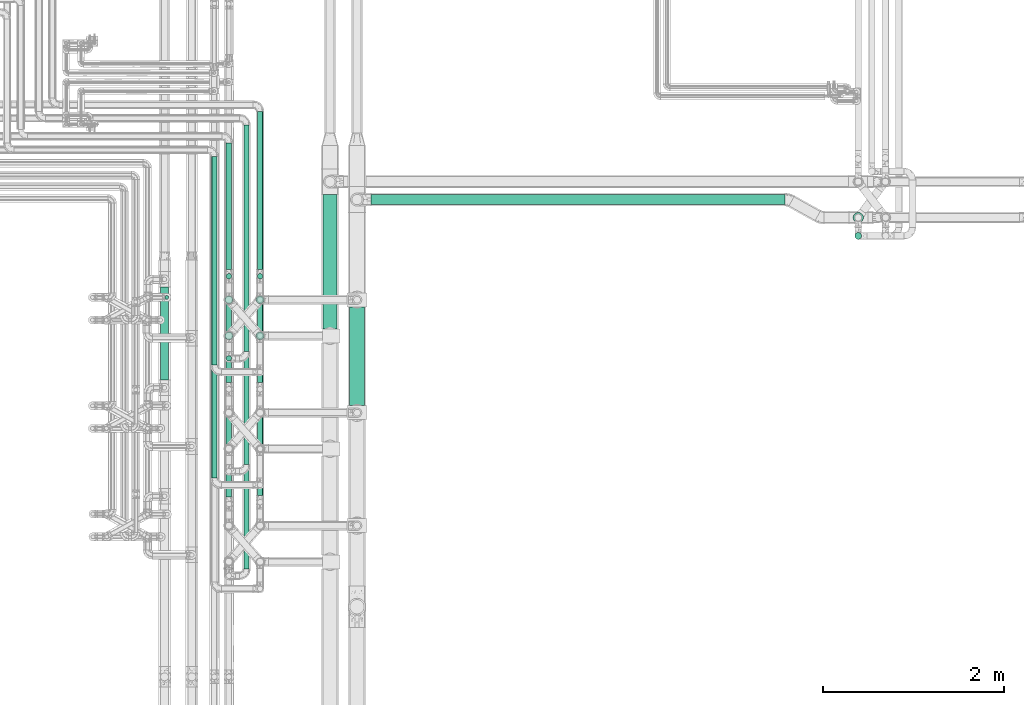
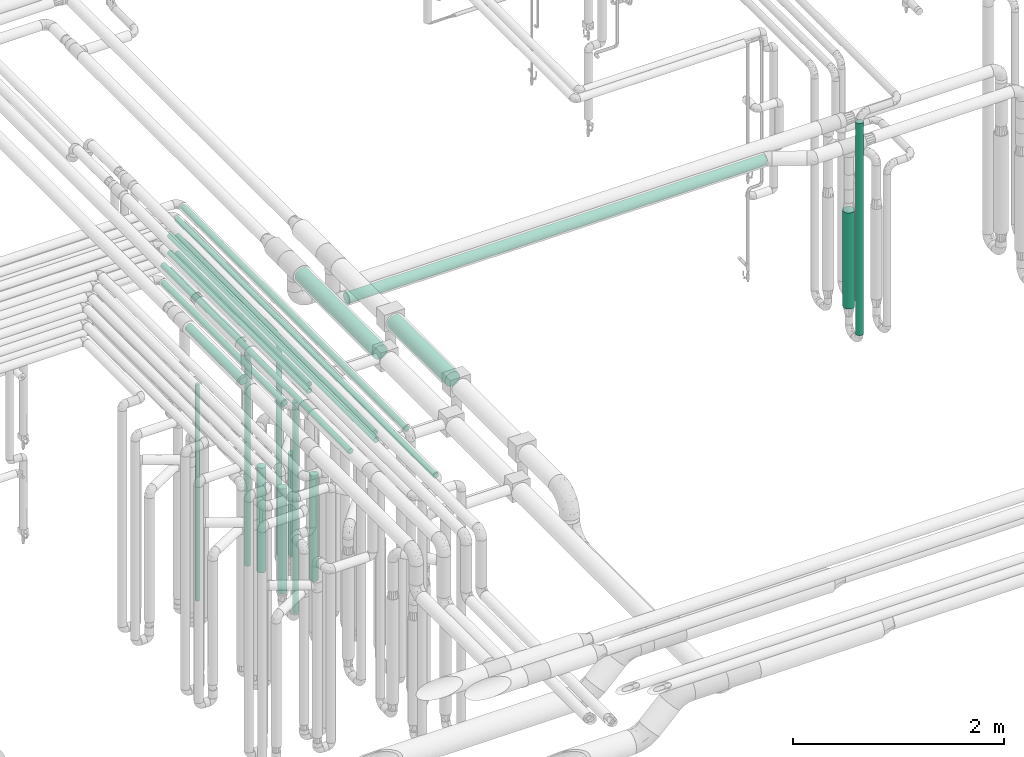
# One storey, part 531 of 827: 25 flow segments.
"""IFC2X3 building model written with IfcOpenShell, lengths in millimetres."""

from ifc_helpers import new_model, entity, si_unit, converted_unit, derived_unit, direction, frame, origin, origin_2d_with_axis, place, context, subcontext, project, spatial, circle, extrude, type_object, element, save


model = new_model("IFC2X3")

# Units and contexts
model_context = context("Model", 3, precision=0.01, world=origin(), true_north=direction((6.12303176911189e-17, 1.0)))
body_context = subcontext(model_context, "Body", "Model", "MODEL_VIEW")
ifc_project = project(units=[si_unit("LENGTHUNIT", "METRE", prefix="MILLI"), si_unit("AREAUNIT", "SQUARE_METRE"), si_unit("VOLUMEUNIT", "CUBIC_METRE"), converted_unit("PLANEANGLEUNIT", "DEGREE", entity("IfcRatioMeasure", 0.0174532925199433), si_unit("PLANEANGLEUNIT", "RADIAN"), dimensions=[0, 0, 0, 0, 0, 0, 0]), si_unit("MASSUNIT", "GRAM", prefix="KILO"), derived_unit("MASSDENSITYUNIT", [(si_unit("MASSUNIT", "GRAM", prefix="KILO"), 1), (si_unit("LENGTHUNIT", "METRE"), -3)]), derived_unit("MOMENTOFINERTIAUNIT", [(si_unit("LENGTHUNIT", "METRE"), 4)]), si_unit("TIMEUNIT", "SECOND"), si_unit("FREQUENCYUNIT", "HERTZ"), si_unit("THERMODYNAMICTEMPERATUREUNIT", "DEGREE_CELSIUS"), derived_unit("THERMALTRANSMITTANCEUNIT", [(si_unit("MASSUNIT", "GRAM", prefix="KILO"), 1), (si_unit("THERMODYNAMICTEMPERATUREUNIT", "KELVIN"), -1), (si_unit("TIMEUNIT", "SECOND"), -3)]), derived_unit("VOLUMETRICFLOWRATEUNIT", [(si_unit("LENGTHUNIT", "METRE"), 3), (si_unit("TIMEUNIT", "SECOND"), -1)]), derived_unit("MASSFLOWRATEUNIT", [(si_unit("MASSUNIT", "GRAM", prefix="KILO"), 1), (si_unit("TIMEUNIT", "SECOND"), -1)]), derived_unit("ROTATIONALFREQUENCYUNIT", [(si_unit("TIMEUNIT", "SECOND"), -1)]), si_unit("ELECTRICCURRENTUNIT", "AMPERE"), si_unit("ELECTRICVOLTAGEUNIT", "VOLT"), si_unit("POWERUNIT", "WATT"), si_unit("FORCEUNIT", "NEWTON", prefix="KILO"), si_unit("ILLUMINANCEUNIT", "LUX"), si_unit("LUMINOUSFLUXUNIT", "LUMEN"), si_unit("LUMINOUSINTENSITYUNIT", "CANDELA"), derived_unit("USERDEFINED", [(si_unit("MASSUNIT", "GRAM", prefix="KILO"), -1), (si_unit("LENGTHUNIT", "METRE"), -2), (si_unit("TIMEUNIT", "SECOND"), 3), (si_unit("LUMINOUSFLUXUNIT", "LUMEN"), 1)]), derived_unit("LINEARVELOCITYUNIT", [(si_unit("LENGTHUNIT", "METRE"), 1), (si_unit("TIMEUNIT", "SECOND"), -1)]), si_unit("PRESSUREUNIT", "PASCAL"), derived_unit("USERDEFINED", [(si_unit("LENGTHUNIT", "METRE"), -2), (si_unit("MASSUNIT", "GRAM", prefix="KILO"), 1), (si_unit("TIMEUNIT", "SECOND"), -2)]), derived_unit("LINEARFORCEUNIT", [(si_unit("MASSUNIT", "GRAM", prefix="KILO"), 1), (si_unit("LENGTHUNIT", "METRE"), 1), (si_unit("TIMEUNIT", "SECOND"), -2), (si_unit("LENGTHUNIT", "METRE"), -1)]), derived_unit("PLANARFORCEUNIT", [(si_unit("MASSUNIT", "GRAM", prefix="KILO"), 1), (si_unit("LENGTHUNIT", "METRE"), 1), (si_unit("TIMEUNIT", "SECOND"), -2), (si_unit("LENGTHUNIT", "METRE"), -2)])], contexts=[model_context])

# Site, building, storey
site_placement = place(None, origin())
site = spatial("IfcSite", under=ifc_project, at=site_placement, CompositionType="ELEMENT")
building_placement = place(site_placement, origin())
building = spatial("IfcBuilding", under=site, at=building_placement, CompositionType="ELEMENT")
storey_placement = place(building_placement, frame((0.0, 0.0, 28200.0)))
storey = spatial("IfcBuildingStorey", under=building, at=storey_placement, Name="08", CompositionType="ELEMENT", Elevation=28200.0)

# Flow segments
pipe_segment_type_1 = type_object("IfcPipeSegmentType", PredefinedType="NOTDEFINED")
flow_segment_1_placement = place(storey_placement, frame((37667.2, 12658.67, 2818.81)))
element("IfcFlowSegment", 1, at=flow_segment_1_placement, inside=storey, type_object=pipe_segment_type_1, context=body_context, shape_type="SweptSolid", body=[
    extrude(circle(Radius=79.5, at=origin_2d_with_axis()), frame((81.1, 0.0, 81.1), z_axis=(0.0, 1.0, 0.0), x_axis=(1.0, 0.0, 0.0)), (0.0, 0.0, 1.0), 1484.9489797613),
])
pipe_segment_type_2 = type_object("IfcPipeSegmentType", PredefinedType="NOTDEFINED")
flow_segment_2_placement = place(storey_placement, frame((38200.3, 14030.32, 2441.4)))
element("IfcFlowSegment", 2, at=flow_segment_2_placement, inside=storey, type_object=pipe_segment_type_2, context=body_context, shape_type="SweptSolid", body=[
    extrude(circle(Radius=57.0, at=origin_2d_with_axis()), frame((0.0, 58.6, 58.6), z_axis=(1.0, 0.0, 0.0), x_axis=(0.0, 1.0, 0.0)), (0.0, 0.0, 1.0), 4582.2791782302),
])
flow_segment_3_placement = place(storey_placement, frame((43556.18, 13647.49, 445.0)))
element("IfcFlowSegment", 3, at=flow_segment_3_placement, inside=storey, type_object=pipe_segment_type_2, context=body_context, shape_type="SweptSolid", body=[
    extrude(circle(Radius=37.75, at=origin_2d_with_axis()), frame((39.35, 39.35, 0.0), z_axis=(0.0, 0.0, 1.0), x_axis=(-1.0, 0.0, 0.0)), (0.0, 0.0, 1.0), 2460.0),
])
flow_segment_4_placement = place(storey_placement, frame((36438.44, 12257.17, 2968.4)))
element("IfcFlowSegment", 4, at=flow_segment_4_placement, inside=storey, type_object=pipe_segment_type_2, context=body_context, shape_type="SweptSolid", body=[
    extrude(circle(Radius=30.0, at=origin_2d_with_axis()), frame((31.6, 0.0, 31.6), z_axis=(0.0, 1.0, 0.0), x_axis=(1.0, 0.0, 0.0)), (0.0, 0.0, 1.0), 2306.8258040542),
])
flow_segment_5_placement = place(storey_placement, frame((36943.44, 13316.2, 2968.4)))
element("IfcFlowSegment", 5, at=flow_segment_5_placement, inside=storey, type_object=pipe_segment_type_2, context=body_context, shape_type="SweptSolid", body=[
    extrude(circle(Radius=30.0, at=origin_2d_with_axis()), frame((31.6, 0.0, 31.6), z_axis=(0.0, 1.0, 0.0), x_axis=(1.0, 0.0, 0.0)), (0.0, 0.0, 1.0), 1746.7974740542),
])
flow_segment_6_placement = place(storey_placement, frame((36793.44, 12407.17, 2968.4)))
element("IfcFlowSegment", 6, at=flow_segment_6_placement, inside=storey, type_object=pipe_segment_type_2, context=body_context, shape_type="SweptSolid", body=[
    extrude(circle(Radius=30.0, at=origin_2d_with_axis()), frame((31.6, 0.0, 31.6), z_axis=(0.0, 1.0, 0.0), x_axis=(-1.0, 0.0, 0.0)), (0.0, 0.0, 1.0), 2505.82601323927),
])
flow_segment_7_placement = place(storey_placement, frame((36598.05, 13316.2, 2968.4)))
element("IfcFlowSegment", 7, at=flow_segment_7_placement, inside=storey, type_object=pipe_segment_type_2, context=body_context, shape_type="SweptSolid", body=[
    extrude(circle(Radius=30.0, at=origin_2d_with_axis()), frame((31.6, 0.0, 31.6), z_axis=(0.0, 1.0, 0.0), x_axis=(-1.0, 0.0, 0.0)), (0.0, 0.0, 1.0), 1397.79727405418),
])
flow_segment_8_placement = place(storey_placement, frame((35920.3, 12983.46, 448.0)))
element("IfcFlowSegment", 8, at=flow_segment_8_placement, inside=storey, type_object=pipe_segment_type_2, context=body_context, shape_type="SweptSolid", body=[
    extrude(circle(Radius=21.15, at=origin_2d_with_axis()), frame((22.75, 22.75, 0.0)), (0.0, 0.0, 1.0), 2504.0),
])
flow_segment_9_placement = place(storey_placement, frame((36598.05, 13208.61, 476.0)))
element("IfcFlowSegment", 9, at=flow_segment_9_placement, inside=storey, type_object=pipe_segment_type_2, context=body_context, shape_type="SweptSolid", body=[
    extrude(circle(Radius=30.0, at=origin_2d_with_axis()), frame((31.6, 31.6, 0.0)), (0.0, 0.0, 1.0), 2447.99999999999),
])
flow_segment_10_placement = place(storey_placement, frame((36943.44, 13208.61, 476.0)))
element("IfcFlowSegment", 10, at=flow_segment_10_placement, inside=storey, type_object=pipe_segment_type_2, context=body_context, shape_type="SweptSolid", body=[
    extrude(circle(Radius=30.0, at=origin_2d_with_axis()), frame((31.6, 31.6, 0.0)), (0.0, 0.0, 1.0), 2448.0),
])
flow_segment_11_placement = place(storey_placement, frame((36598.05, 12299.58, 476.0)))
element("IfcFlowSegment", 11, at=flow_segment_11_placement, inside=storey, type_object=pipe_segment_type_2, context=body_context, shape_type="SweptSolid", body=[
    extrude(circle(Radius=30.0, at=origin_2d_with_axis()), frame((31.6, 31.6, 0.0), z_axis=(0.0, 0.0, 1.0), x_axis=(-1.0, 0.0, 0.0)), (0.0, 0.0, 1.0), 2447.99999099998),
])
flow_segment_12_placement = place(storey_placement, frame((36438.44, 11007.17, 3168.4)))
element("IfcFlowSegment", 12, at=flow_segment_12_placement, inside=storey, type_object=pipe_segment_type_2, context=body_context, shape_type="SweptSolid", body=[
    extrude(circle(Radius=30.0, at=origin_2d_with_axis()), frame((31.6, 0.0, 31.6), z_axis=(0.0, 1.0, 0.0), x_axis=(1.0, 0.0, 0.0)), (0.0, 0.0, 1.0), 3556.82579505427),
])
flow_segment_13_placement = place(storey_placement, frame((36943.44, 12066.2, 3168.4)))
element("IfcFlowSegment", 13, at=flow_segment_13_placement, inside=storey, type_object=pipe_segment_type_2, context=body_context, shape_type="SweptSolid", body=[
    extrude(circle(Radius=30.0, at=origin_2d_with_axis()), frame((31.6, 0.0, 31.6), z_axis=(0.0, 1.0, 0.0), x_axis=(1.0, 0.0, 0.0)), (0.0, 0.0, 1.0), 2996.79746505423),
])
flow_segment_14_placement = place(storey_placement, frame((36793.44, 11157.17, 3168.4)))
element("IfcFlowSegment", 14, at=flow_segment_14_placement, inside=storey, type_object=pipe_segment_type_2, context=body_context, shape_type="SweptSolid", body=[
    extrude(circle(Radius=30.0, at=origin_2d_with_axis()), frame((31.6, 0.0, 31.6), z_axis=(0.0, 1.0, 0.0), x_axis=(1.0, 0.0, 0.0)), (0.0, 0.0, 1.0), 3755.82600423931),
])
flow_segment_15_placement = place(storey_placement, frame((36598.05, 12066.2, 3168.4)))
element("IfcFlowSegment", 15, at=flow_segment_15_placement, inside=storey, type_object=pipe_segment_type_2, context=body_context, shape_type="SweptSolid", body=[
    extrude(circle(Radius=30.0, at=origin_2d_with_axis()), frame((31.6, 0.0, 31.6), z_axis=(0.0, 1.0, 0.0), x_axis=(-1.0, 0.0, 0.0)), (0.0, 0.0, 1.0), 2647.79726505419),
])
flow_segment_16_placement = place(storey_placement, frame((36943.44, 10816.2, 3368.4)))
element("IfcFlowSegment", 16, at=flow_segment_16_placement, inside=storey, type_object=pipe_segment_type_2, context=body_context, shape_type="SweptSolid", body=[
    extrude(circle(Radius=30.0, at=origin_2d_with_axis()), frame((31.6, 0.0, 31.6), z_axis=(0.0, 1.0, 0.0), x_axis=(1.0, 0.0, 0.0)), (0.0, 0.0, 1.0), 4247.79746505422),
])
flow_segment_17_placement = place(storey_placement, frame((36793.44, 10002.17, 3368.4)))
element("IfcFlowSegment", 17, at=flow_segment_17_placement, inside=storey, type_object=pipe_segment_type_2, context=body_context, shape_type="SweptSolid", body=[
    extrude(circle(Radius=30.0, at=origin_2d_with_axis()), frame((31.6, 0.0, 31.6), z_axis=(0.0, 1.0, 0.0), x_axis=(-1.0, 0.0, 0.0)), (0.0, 0.0, 1.0), 4911.82600423926),
])
flow_segment_18_placement = place(storey_placement, frame((36598.05, 10795.72, 3368.4)))
element("IfcFlowSegment", 18, at=flow_segment_18_placement, inside=storey, type_object=pipe_segment_type_2, context=body_context, shape_type="SweptSolid", body=[
    extrude(circle(Radius=30.0, at=origin_2d_with_axis()), frame((31.6, 0.0, 31.6), z_axis=(0.0, 1.0, 0.0), x_axis=(1.0, 0.0, 0.0)), (0.0, 0.0, 1.0), 3918.27777979508),
])
flow_segment_19_placement = place(storey_placement, frame((37964.2, 11807.7, 2915.9)))
element("IfcFlowSegment", 19, at=flow_segment_19_placement, inside=storey, type_object=pipe_segment_type_2, context=body_context, shape_type="SweptSolid", body=[
    extrude(circle(Radius=82.5, at=origin_2d_with_axis()), frame((84.1, 0.0, 84.1), z_axis=(0.0, 1.0, 0.0), x_axis=(-1.0, 0.0, 0.0)), (0.0, 0.0, 1.0), 1094.43742839127),
])
flow_segment_20_placement = place(storey_placement, frame((35872.22, 12092.08, 3504.16)))
element("IfcFlowSegment", 20, at=flow_segment_20_placement, inside=storey, type_object=pipe_segment_type_2, context=body_context, shape_type="SweptSolid", body=[
    extrude(circle(Radius=44.25, at=origin_2d_with_axis()), frame((45.85, 0.0, 45.85), z_axis=(0.0, 1.0, 0.0), x_axis=(-1.0, 0.0, 0.0)), (0.0, 0.0, 1.0), 1028.0),
])
flow_segment_21_placement = place(storey_placement, frame((36929.19, 12535.33, 589.0)))
element("IfcFlowSegment", 21, at=flow_segment_21_placement, inside=storey, type_object=pipe_segment_type_2, context=body_context, shape_type="SweptSolid", body=[
    extrude(circle(Radius=44.25, at=origin_2d_with_axis()), frame((45.85, 45.85, 0.0)), (0.0, 0.0, 1.0), 1222.00000649531),
])
flow_segment_22_placement = place(storey_placement, frame((36929.19, 12933.8, 629.0)))
element("IfcFlowSegment", 22, at=flow_segment_22_placement, inside=storey, type_object=pipe_segment_type_2, context=body_context, shape_type="SweptSolid", body=[
    extrude(circle(Radius=44.25, at=origin_2d_with_axis()), frame((45.85, 45.85, 0.0), z_axis=(0.0, 0.0, 1.0), x_axis=(-1.0, 0.0, 0.0)), (0.0, 0.0, 1.0), 1182.0),
])
flow_segment_23_placement = place(storey_placement, frame((36583.8, 12934.36, 565.0)))
element("IfcFlowSegment", 23, at=flow_segment_23_placement, inside=storey, type_object=pipe_segment_type_2, context=body_context, shape_type="SweptSolid", body=[
    extrude(circle(Radius=44.25, at=origin_2d_with_axis()), frame((45.85, 45.85, 0.0)), (0.0, 0.0, 1.0), 1216.00000000001),
])
flow_segment_24_placement = place(storey_placement, frame((36583.83, 12535.33, 564.99)))
element("IfcFlowSegment", 24, at=flow_segment_24_placement, inside=storey, type_object=pipe_segment_type_2, context=body_context, shape_type="SweptSolid", body=[
    extrude(circle(Radius=44.25, at=origin_2d_with_axis()), frame((45.85, 45.85, 0.01), z_axis=(0.000201513087669316, 0.0, 0.999999979696238), x_axis=(-0.999999979696238, 0.0, 0.000201513087669316)), (0.0, 0.0, 1.0), 1216.00001903948),
])
flow_segment_25_placement = place(storey_placement, frame((43536.93, 13831.58, 643.02)))
element("IfcFlowSegment", 25, at=flow_segment_25_placement, inside=storey, type_object=pipe_segment_type_2, context=body_context, shape_type="SweptSolid", body=[
    extrude(circle(Radius=57.0, at=origin_2d_with_axis()), frame((58.6, 58.6, 0.0)), (0.0, 0.0, 1.0), 1114.97846391128),
])

save(model, "model.ifc")
